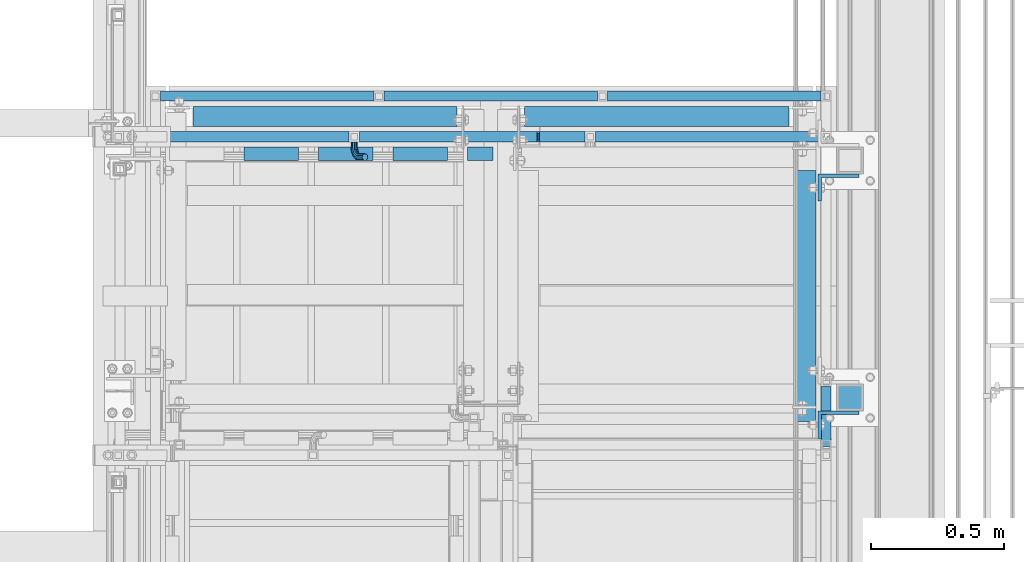
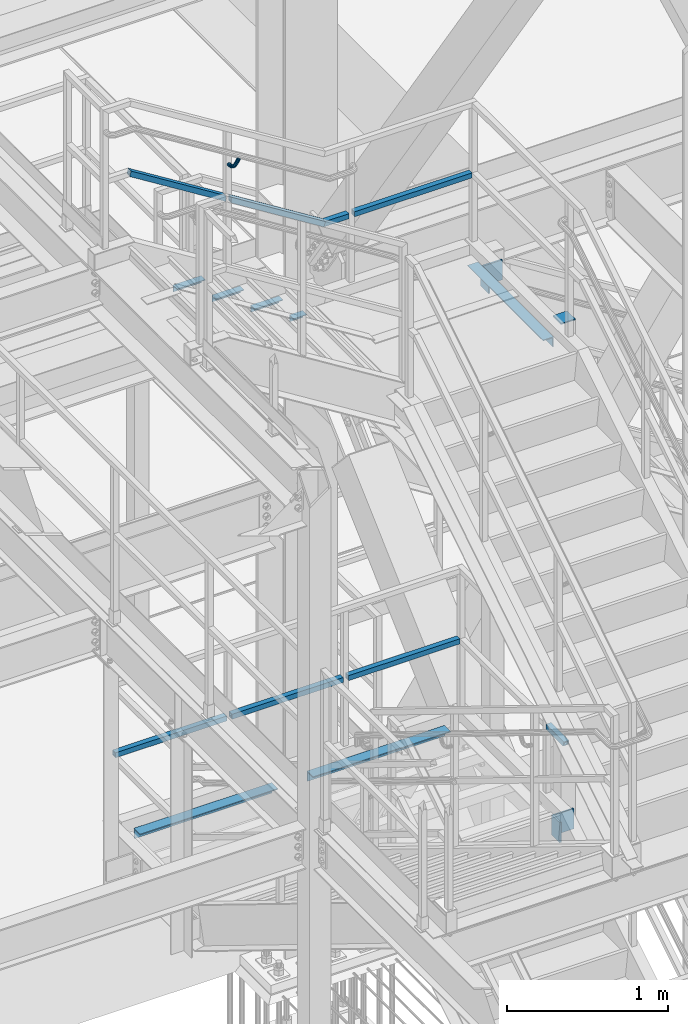
# One storey, part 2098 of 3843: 17 beams, 2 members, 8 elements without a shape of their own.
"""IFC2X3 building model written with IfcOpenShell, lengths in millimetres."""

from ifc_helpers import new_model, si_unit, frame, origin_with_axes, place, context, subcontext, project, spatial, faceted_brep, material, type_object, element, aggregate, save


model = new_model("IFC2X3")

# Units and contexts
model_context = context("Model", 3, precision=1e-05, world=origin_with_axes())
body_context = subcontext(model_context, "Body", "Model", "MODEL_VIEW")
ifc_project = project(units=[si_unit("LENGTHUNIT", "METRE", prefix="MILLI"), si_unit("AREAUNIT", "SQUARE_METRE"), si_unit("VOLUMEUNIT", "CUBIC_METRE"), si_unit("MASSUNIT", "GRAM", prefix="KILO"), si_unit("TIMEUNIT", "SECOND"), si_unit("PLANEANGLEUNIT", "RADIAN"), si_unit("SOLIDANGLEUNIT", "STERADIAN"), si_unit("THERMODYNAMICTEMPERATUREUNIT", "DEGREE_CELSIUS"), si_unit("LUMINOUSINTENSITYUNIT", "LUMEN")], contexts=[model_context])

# Site, building, storey
site_placement = place(None, origin_with_axes())
site = spatial("IfcSite", under=ifc_project, at=site_placement, CompositionType="ELEMENT")
building_placement = place(site_placement, origin_with_axes())
building = spatial("IfcBuilding", under=site, at=building_placement, Name="Undefined", CompositionType="ELEMENT")
storey_placement = place(building_placement, origin_with_axes())
storey = spatial("IfcBuildingStorey", under=building, at=storey_placement, Name="Undefined", CompositionType="ELEMENT", Elevation=0.0)

# Assembly, beams
assembly_1_placement = place(storey_placement, origin_with_axes())
assembly_1 = element("IfcElementAssembly", 1, at=assembly_1_placement, inside=storey, Name="RAIL", AssemblyPlace="NOTDEFINED", PredefinedType="RIGID_FRAME")
ifc_material_1 = material()
beam_type_1 = type_object("IfcBeamType", Name="HSS1-1/2X1-1/2X1/4", PredefinedType="NOTDEFINED")
beam_1_placement = place(assembly_1_placement, frame((54753.9333333087, 22910.8000000104, 37227.933331298), z_axis=(0.0, 0.0, 1.0), x_axis=(-1.0, 0.0, 0.0)))
beam_1 = element("IfcBeam", 2, at=beam_1_placement, type_object=beam_type_1, material=ifc_material_1, Name="RAIL", ObjectType="HSS1-1/2X1-1/2X1/4", context=body_context, shape_type="Brep", body=[
    faceted_brep([(19.0499992350015, -19.0499992350015, -19.0499992350015), (19.0499992350015, -19.0499992350015, 19.0499992350015), (19.0499992350015, 19.0499992350015, 19.0499992350015), (19.0499992350015, 19.0499992350015, -19.0499992350015), (19.0499992350015, 12.6999993299978, 12.6999993299978), (19.0499992350015, -12.6999993299978, 12.6999993299978), (19.0499992350015, -12.6999993299978, -12.6999993299978), (19.0499992350015, 12.6999993299978, -12.6999993299978), (200.1911839924, 19.0499992350015, -19.0499992350015), (200.1911839924, -19.0499992350015, -19.0499992350015), (189.275482698868, -19.0499992350015, 19.0499992350015), (189.275482698868, 19.0499992350015, 19.0499992350015), (191.094766293631, -12.6999993300014, 12.6999993299978), (191.094766293631, 12.6999993300014, 12.6999993299978), (198.371900397637, 12.6999993300014, -12.6999993299978), (198.371900397637, -12.6999993300014, -12.6999993299978)], [[[0, 1, 2, 3], [4, 5, 6, 7]], [[8, 9, 0, 3]], [[9, 10, 1, 0]], [[10, 11, 2, 1]], [[11, 8, 3, 2]], [[10, 9, 8, 11], [12, 13, 14, 15]], [[13, 12, 5, 4]], [[14, 13, 4, 7]], [[15, 14, 7, 6]], [[12, 15, 6, 5]]]),
])
beam_2_placement = place(assembly_1_placement, frame((55638.7, 22910.8000000047, 37227.933331298), z_axis=(0.0, 0.0, 1.0), x_axis=(-1.0, 0.0, 0.0)))
beam_2 = element("IfcBeam", 3, at=beam_2_placement, type_object=beam_type_1, material=ifc_material_1, Name="RAIL", ObjectType="HSS1-1/2X1-1/2X1/4", context=body_context, shape_type="Brep", body=[
    faceted_brep([(865.716666687869, -19.0500000104294, 19.0499992350015), (865.716666687869, -19.0499992350015, -19.0499992350015), (865.716666687869, 19.0499992350015, -19.0499992350015), (865.716666687869, 19.0499992518344, 19.0499992350015), (865.716666687869, -12.6999993300014, 12.6999993299978), (865.716666687869, 12.6999993300014, 12.6999993299978), (865.716666687869, 12.6999993300014, -12.6999993299978), (865.716666687869, -12.6999993300014, -12.6999993299978), (19.0499992350015, 19.0499992350015, -19.0499992350015), (19.0499992350015, 19.0499992350015, 19.0499992350015), (19.0499992350015, -19.0499992350015, 19.0499992350015), (19.0499992350015, -19.0499992350015, -19.0499992350015), (19.0499992350015, 12.6999993299978, 12.6999993299978), (19.0499992350015, -12.6999993299978, 12.6999993299978), (19.0499992350015, -12.6999993299978, -12.6999993299978), (19.0499992350015, 12.6999993299978, -12.6999993299978)], [[[0, 1, 2, 3], [4, 5, 6, 7]], [[8, 9, 3, 2]], [[9, 10, 0, 3]], [[10, 11, 1, 0]], [[11, 8, 2, 1]], [[11, 10, 9, 8], [12, 13, 14, 15]], [[14, 13, 4, 7]], [[15, 14, 7, 6]], [[12, 15, 6, 5]], [[13, 12, 5, 4]]]),
])

assembly_2_placement = place(storey_placement, origin_with_axes())
assembly_2 = element("IfcElementAssembly", 4, at=assembly_2_placement, inside=storey, Name="RAIL", AssemblyPlace="NOTDEFINED", PredefinedType="RIGID_FRAME")
beam_3_placement = place(assembly_2_placement, frame((53962.2999999994, 23063.2000000032, 33592.4769212707), z_axis=(0.0, 0.0, 1.0), x_axis=(1.0, 0.0, 0.0)))
beam_3 = element("IfcBeam", 5, at=beam_3_placement, type_object=beam_type_1, material=ifc_material_1, Name="RAIL", ObjectType="HSS1-1/2X1-1/2X1/4", context=body_context, shape_type="Brep", body=[
    faceted_brep([(19.0499992350015, 12.6999993299978, -12.6999993299978), (19.0499992350015, -12.6999993299978, -12.6999993299978), (819.150000000322, -12.6999993300014, -12.6999993299978), (819.150000000322, 12.6999993300014, -12.6999993299978), (19.0499992350015, -12.6999993299978, 12.6999993299978), (819.150000000322, -12.6999993300014, 12.6999993299978), (19.0499992350015, 12.6999993299978, 12.6999993299978), (819.150000000322, 12.6999993300014, 12.6999993299978), (19.0499992350015, 19.0499992350015, -19.0499992350015), (19.0499992350015, 19.0499992350015, 19.0499992350015), (819.150000000322, 19.0499992350015, 19.0499992350015), (819.150000000322, 19.0499992350015, -19.0499992350015), (19.0499992350015, -19.0499992350015, 19.0499992350015), (819.150000000322, -19.0499992350015, 19.0499992350015), (19.0499992350015, -19.0499992350015, -19.0499992350015), (819.150000000322, -19.0499992350015, -19.0499992350015)], [[[0, 1, 2, 3]], [[1, 4, 5, 2]], [[4, 6, 7, 5]], [[6, 0, 3, 7]], [[8, 9, 10, 11]], [[9, 12, 13, 10]], [[12, 14, 15, 13]], [[14, 8, 11, 15]], [[13, 15, 11, 10], [5, 7, 3, 2]], [[14, 12, 9, 8], [6, 4, 1, 0]]]),
])
beam_4_placement = place(assembly_2_placement, frame((53124.1, 23063.1999999956, 33592.4769213313), z_axis=(0.0, 0.0, 1.0), x_axis=(1.0, 0.0, 0.0)))
beam_4 = element("IfcBeam", 6, at=beam_4_placement, type_object=beam_type_1, material=ifc_material_1, Name="RAIL", ObjectType="HSS1-1/2X1-1/2X1/4", context=body_context, shape_type="Brep", body=[
    faceted_brep([(19.0499992350015, 12.6999993299978, -12.6999993299978), (19.0499992350015, -12.6999993299978, -12.6999993299978), (819.150000000322, -12.6999993300014, -12.6999993299978), (819.150000000322, 12.6999993300014, -12.6999993299978), (19.0499992350015, -12.6999993299978, 12.6999993299978), (819.150000000322, -12.6999993300014, 12.6999993299978), (19.0499992350015, 12.6999993299978, 12.6999993299978), (819.150000000322, 12.6999993300014, 12.6999993299978), (19.0499992350015, 19.0499992350015, -19.0499992350015), (19.0499992350015, 19.0499992350015, 19.0499992350015), (819.150000000322, 19.0499992350015, 19.0499992350015), (819.150000000322, 19.0499992350015, -19.0499992350015), (19.0499992350015, -19.0499992350015, 19.0499992350015), (819.150000000322, -19.0499992350015, 19.0499992350015), (19.0499992350015, -19.0499992350015, -19.0499992350015), (819.150000000322, -19.0499992350015, -19.0499992350015)], [[[0, 1, 2, 3]], [[1, 4, 5, 2]], [[4, 6, 7, 5]], [[6, 0, 3, 7]], [[8, 9, 10, 11]], [[9, 12, 13, 10]], [[12, 14, 15, 13]], [[14, 8, 11, 15]], [[13, 15, 11, 10], [5, 7, 3, 2]], [[14, 12, 9, 8], [6, 4, 1, 0]]]),
])
beam_5_placement = place(assembly_2_placement, frame((54800.4999999997, 23063.2000000032, 33592.4769212707), z_axis=(0.0, 0.0, 1.0), x_axis=(1.0, 0.0, 0.0)))
beam_5 = element("IfcBeam", 7, at=beam_5_placement, type_object=beam_type_1, material=ifc_material_1, Name="RAIL", ObjectType="HSS1-1/2X1-1/2X1/4", context=body_context, shape_type="Brep", body=[
    faceted_brep([(19.0499992350015, 12.6999993299978, -12.6999993299978), (19.0499992350015, -12.6999993299978, -12.6999993299978), (819.150000000322, -12.6999993300014, -12.6999993299978), (819.150000000322, 12.6999993300014, -12.6999993299978), (19.0499992350015, -12.6999993299978, 12.6999993299978), (819.150000000322, -12.6999993300014, 12.6999993299978), (19.0499992350015, 12.6999993299978, 12.6999993299978), (819.150000000322, 12.6999993300014, 12.6999993299978), (19.0499992350015, 19.0499992350015, -19.0499992350015), (19.0499992350015, 19.0499992350015, 19.0499992350015), (819.150000000322, 19.0499992350015, 19.0499992350015), (819.150000000322, 19.0499992350015, -19.0499992350015), (19.0499992350015, -19.0499992350015, 19.0499992350015), (819.150000000322, -19.0499992350015, 19.0499992350015), (19.0499992350015, -19.0499992350015, -19.0499992350015), (819.150000000322, -19.0499992350015, -19.0499992350015)], [[[0, 1, 2, 3]], [[1, 4, 5, 2]], [[4, 6, 7, 5]], [[6, 0, 3, 7]], [[8, 9, 10, 11]], [[9, 12, 13, 10]], [[12, 14, 15, 13]], [[14, 8, 11, 15]], [[13, 15, 11, 10], [5, 7, 3, 2]], [[14, 12, 9, 8], [6, 4, 1, 0]]]),
])
aggregate(assembly_2, [beam_3, beam_4, beam_5])

# Assembly, beam
assembly_3_placement = place(storey_placement, origin_with_axes())
assembly_3 = element("IfcElementAssembly", 8, at=assembly_3_placement, inside=storey, Name="RAIL", AssemblyPlace="NOTDEFINED", PredefinedType="RIGID_FRAME")
beam_6_placement = place(assembly_3_placement, frame((55638.6999999997, 21755.1000004885, 33592.4769212975), z_axis=(0.0, 0.0, 1.0), x_axis=(0.0, 1.0, 0.0)))
beam_6 = element("IfcBeam", 9, at=beam_6_placement, type_object=beam_type_1, material=ifc_material_1, Name="RAIL", ObjectType="HSS1-1/2X1-1/2X1/4", context=body_context, shape_type="Brep", body=[
    faceted_brep([(3.59463564452017, 12.6999993300014, -12.6999993299978), (3.59463564452017, -12.6999993300014, -12.6999993299978), (219.075000274512, -12.6999993299978, -12.6999993299978), (219.075000274512, 12.6999993299978, -12.6999993299978), (-3.59463560431323, -12.6999993300014, 12.6999993299978), (219.075000274512, -12.6999993299978, 12.6999993299978), (-3.59463560431323, 12.6999993300014, 12.6999993299978), (219.075000274512, 12.6999993299978, 12.6999993299978), (5.39195352466777, 19.0499992350015, -19.0499992350015), (-5.39195348444628, 19.0499992350015, 19.0499992350015), (219.075000274512, 19.0499992350015, 19.0499992350015), (219.075000274512, 19.0499992350015, -19.0499992350015), (-5.39195348444628, -19.0499992350015, 19.0499992350015), (219.075000274512, -19.0499992350015, 19.0499992350015), (5.39195352466777, -19.0499992350015, -19.0499992350015), (219.075000274512, -19.0499992350015, -19.0499992350015)], [[[0, 1, 2, 3]], [[1, 4, 5, 2]], [[4, 6, 7, 5]], [[6, 0, 3, 7]], [[8, 9, 10, 11]], [[9, 12, 13, 10]], [[12, 14, 15, 13]], [[14, 8, 11, 15]], [[13, 15, 11, 10], [5, 7, 3, 2]], [[14, 12, 9, 8], [6, 4, 1, 0]]]),
])
aggregate(assembly_3, [beam_6])

assembly_4_placement = place(storey_placement, origin_with_axes())
assembly_4 = element("IfcElementAssembly", 10, at=assembly_4_placement, inside=storey, Name="POST", AssemblyPlace="NOTDEFINED", PredefinedType="RIGID_FRAME")
ifc_material_2 = material(Name="STEEL/A36")
beam_type_2 = type_object("IfcBeamType", Name="L6X4X1/2", PredefinedType="NOTDEFINED")
beam_7_placement = place(assembly_4_placement, frame((55684.737500001, 21831.3000000032, 32982.8769213273), z_axis=(1.0, 0.0, 0.0), x_axis=(0.0, 0.0, -1.0)))
beam_7 = element("IfcBeam", 11, at=beam_7_placement, type_object=beam_type_2, material=ifc_material_2, Name="ANGLE", ObjectType="L6X4X1/2", context=body_context, shape_type="Brep", body=[
    faceted_brep([(0.0, 50.7999999999993, -76.1999999999971), (0.0, 50.7999999999993, 76.1999999999971), (152.399999999994, 50.7999999999993, 76.1999999999971), (152.399999999994, 50.7999999999993, -76.1999999999971), (0.0, 38.0999999999985, 76.1999999999971), (152.399999999994, 38.0999999999985, 76.1999999999971), (0.0, 38.0999999999985, -63.5), (152.399999999994, 38.0999999999985, -63.5), (0.0, -50.7999999999993, -63.5), (152.399999999994, -50.7999999999993, -63.5), (0.0, -50.7999999999993, -76.1999999999971), (152.399999999994, -50.7999999999993, -76.1999999999971)], [[[0, 1, 2, 3]], [[1, 4, 5, 2]], [[4, 6, 7, 5]], [[6, 8, 9, 7]], [[8, 10, 11, 9]], [[10, 0, 3, 11]], [[5, 7, 9, 11, 3, 2]], [[10, 8, 6, 4, 1, 0]]]),
])

assembly_5_placement = place(storey_placement, origin_with_axes())
assembly_5 = element("IfcElementAssembly", 12, at=assembly_5_placement, inside=storey, Name="POST", AssemblyPlace="NOTDEFINED", PredefinedType="RIGID_FRAME")
beam_8_placement = place(assembly_5_placement, frame((55684.737500001, 22720.3000000818, 36618.3333313492), z_axis=(1.0, 0.0, 0.0), x_axis=(0.0, 0.0, -1.0)))
beam_8 = element("IfcBeam", 13, at=beam_8_placement, type_object=beam_type_2, material=ifc_material_2, Name="ANGLE", ObjectType="L6X4X1/2", context=body_context, shape_type="Brep", body=[
    faceted_brep([(0.0, 50.7999999999993, -76.1999999999971), (0.0, 50.7999999999993, 76.1999999999971), (152.399999999994, 50.7999999999993, 76.1999999999971), (152.399999999994, 50.7999999999993, -76.1999999999971), (0.0, 38.0999999999985, 76.1999999999971), (152.399999999994, 38.0999999999985, 76.1999999999971), (0.0, 38.0999999999985, -63.5), (152.399999999994, 38.0999999999985, -63.5), (0.0, -50.7999999999993, -63.5), (152.399999999994, -50.7999999999993, -63.5), (0.0, -50.7999999999993, -76.1999999999971), (152.399999999994, -50.7999999999993, -76.1999999999971)], [[[0, 1, 2, 3]], [[1, 4, 5, 2]], [[4, 6, 7, 5]], [[6, 8, 9, 7]], [[8, 10, 11, 9]], [[10, 0, 3, 11]], [[5, 7, 9, 11, 3, 2]], [[10, 8, 6, 4, 1, 0]]]),
])
aggregate(assembly_5, [beam_8])

# Member
member_type = type_object("IfcMemberType", Name="HSS1-1/2X1-1/2X1/4", PredefinedType="NOTDEFINED")
member_1_placement = place(assembly_1_placement, frame((53869.1666666233, 22910.8000000151, 37658.6814120453), z_axis=(0.529536736899108, 0.0, 0.848287005838381), x_axis=(-0.848287005838377, 0.0, 0.529536736899114)))
member_1 = element("IfcMember", 14, at=member_1_placement, type_object=member_type, material=ifc_material_1, Name="RAIL", ObjectType="HSS1-1/2X1-1/2X1/4", context=body_context, shape_type="Brep", body=[
    faceted_brep([(34.3488397583606, -19.0499999999956, 19.0499992348923), (34.3488397583606, 19.0499992350015, 19.0499992348923), (10.5652043534537, 19.0499992350015, -19.0499992349432), (10.5652043534537, -19.0499992350015, -19.0499992349432), (30.3849004243275, -12.6999993300014, 12.6999993299178), (14.5291436874832, -12.6999993300014, -12.6999993299687), (14.5291436874832, 12.6999993300014, -12.6999993299687), (30.3849004243275, 12.6999993300014, 12.6999993299178), (827.947191084055, 19.0499992350015, -19.0499992358964), (827.947191084055, -19.0499992350015, -19.0499992358964), (838.862892383193, -19.0499992350015, 19.049999233961), (838.862892383193, 19.0499992350015, 19.049999233961), (837.043608787495, -12.6999993300014, 12.6999993289792), (837.043608787495, 12.6999993300014, 12.6999993289792), (829.766474679749, 12.6999993300014, -12.6999993309219), (829.766474679749, -12.6999993300014, -12.6999993309219)], [[[0, 1, 2, 3], [4, 5, 6, 7]], [[8, 9, 3, 2]], [[9, 10, 0, 3]], [[10, 11, 1, 0]], [[11, 8, 2, 1]], [[10, 9, 8, 11], [12, 13, 14, 15]], [[13, 12, 4, 7]], [[14, 13, 7, 6]], [[15, 14, 6, 5]], [[12, 15, 5, 4]]]),
])

member_2_placement = place(assembly_1_placement, frame((54559.1999999617, 22910.8000000151, 37227.933331298), z_axis=(0.529536736899108, 0.0, 0.848287005838381), x_axis=(-0.848287005838377, 0.0, 0.529536736899114)))
member_2 = element("IfcMember", 15, at=member_2_placement, type_object=member_type, material=ifc_material_1, Name="RAIL", ObjectType="HSS1-1/2X1-1/2X1/4", context=body_context, shape_type="Brep", body=[
    faceted_brep([(802.87803901095, -19.0499999999993, 19.0499992339901), (779.094403606043, -19.0499992350015, -19.0499992358382), (779.094403606043, 19.0499992350015, -19.0499992358382), (802.87803901095, 19.0499992350015, 19.0499992339901), (798.914099676924, -12.6999993300014, 12.6999993290228), (798.914099676924, 12.6999993300014, 12.6999993290228), (783.058342940076, 12.6999993300014, -12.6999993308709), (783.058342940076, -12.6999993300014, -12.6999993308709), (5.45785064817028, 19.0499992350015, 19.0499992349287), (5.45785064817028, -19.0499992350015, 19.0499992349287), (-5.45785065095697, -19.0499992350015, -19.0499992349214), (-5.45785065095697, 19.0499992350015, -19.0499992349214), (3.63856705247599, 12.6999993300014, 12.6999993299542), (3.63856705247599, -12.6999993300014, 12.6999993299542), (-3.63856705526268, -12.6999993300014, -12.6999993299469), (-3.63856705526268, 12.6999993300014, -12.6999993299469)], [[[0, 1, 2, 3], [4, 5, 6, 7]], [[8, 9, 0, 3]], [[10, 11, 2, 1]], [[9, 10, 1, 0]], [[11, 8, 3, 2]], [[10, 9, 8, 11], [12, 13, 14, 15]], [[14, 13, 4, 7]], [[15, 14, 7, 6]], [[12, 15, 6, 5]], [[13, 12, 5, 4]]]),
])

# Assembly, beams
assembly_6_placement = place(storey_placement, origin_with_axes())
assembly_6 = element("IfcElementAssembly", 16, at=assembly_6_placement, inside=storey, Name="STAIR", AssemblyPlace="NOTDEFINED", PredefinedType="RIGID_FRAME")
beam_type_3 = type_object("IfcBeamType", Name="L2X2X3/16", PredefinedType="NOTDEFINED")
beam_9_placement = place(assembly_6_placement, frame((54294.5934500262, 22847.299999903, 36618.3200647423), z_axis=(0.0, -1.0, 0.0), x_axis=(1.0, 0.0, 0.0)))
beam_9 = element("IfcBeam", 17, at=beam_9_placement, type_object=beam_type_3, material=ifc_material_2, Name="ANGLE", ObjectType="L2X2X3/16", context=body_context, shape_type="Brep", body=[
    faceted_brep([(0.0, 25.4000000000015, -25.4000000000015), (0.0, 25.4000000000015, 25.4000000000015), (95.25, 25.4000000000015, 25.4000000000015), (95.25, 25.4000000000015, -25.4000000000015), (0.0, 20.6375000000007, 25.4000000000015), (95.25, 20.6374999999971, 25.4000000000015), (0.0, 20.6375000000007, -20.6375000000007), (95.25, 20.6374999999971, -20.6375000000007), (0.0, -25.4000000000015, -20.6375000000007), (95.25, -25.4000000000015, -20.6375000000007), (0.0, -25.4000000000015, -25.4000000000015), (95.25, -25.4000000000015, -25.4000000000015)], [[[0, 1, 2, 3]], [[1, 4, 5, 2]], [[4, 6, 7, 5]], [[6, 8, 9, 7]], [[8, 10, 11, 9]], [[10, 0, 3, 11]], [[5, 7, 9, 11, 3, 2]], [[10, 8, 6, 4, 1, 0]]]),
])
ifc_material_3 = material(Name="STEEL/A572-50")
beam_10_placement = place(assembly_6_placement, frame((53456.3934500501, 22847.3000000165, 37138.3983316229), z_axis=(0.0, -1.0, 0.0), x_axis=(1.0, 0.0, 0.0)))
beam_10 = element("IfcBeam", 18, at=beam_10_placement, type_object=beam_type_3, material=ifc_material_3, Name="ANGLE", ObjectType="L2X2X3/16", context=body_context, shape_type="Brep", body=[
    faceted_brep([(0.0, 25.4000000000015, -25.4000000000015), (0.0, 25.4000000000015, 25.4000000000015), (203.199999999997, 25.4000000000015, 25.4000000000015), (203.199999999997, 25.4000000000015, -25.4000000000015), (0.0, 20.6375000000007, 25.4000000000015), (203.199999999997, 20.6375000000007, 25.4000000000015), (0.0, 20.6375000000007, -20.6375000000007), (203.199999999997, 20.6375000000007, -20.6375000000007), (0.0, -25.4000000000015, -20.6375000000007), (203.199999999997, -25.4000000000015, -20.6375000000007), (0.0, -25.4000000000015, -25.4000000000015), (203.199999999997, -25.4000000000015, -25.4000000000015)], [[[0, 1, 2, 3]], [[1, 4, 5, 2]], [[4, 6, 7, 5]], [[6, 8, 9, 7]], [[8, 10, 11, 9]], [[10, 0, 3, 11]], [[5, 7, 9, 11, 3, 2]], [[10, 8, 6, 4, 1, 0]]]),
])
beam_11_placement = place(assembly_6_placement, frame((53735.7934500472, 22847.3000000158, 36963.9849981808), z_axis=(0.0, -1.0, 0.0), x_axis=(1.0, 0.0, 0.0)))
beam_11 = element("IfcBeam", 19, at=beam_11_placement, type_object=beam_type_3, material=ifc_material_3, Name="ANGLE", ObjectType="L2X2X3/16", context=body_context, shape_type="Brep", body=[
    faceted_brep([(0.0, 25.4000000000015, -25.4000000000015), (0.0, 25.4000000000015, 25.4000000000015), (203.199999999997, 25.4000000000015, 25.4000000000015), (203.199999999997, 25.4000000000015, -25.4000000000015), (0.0, 20.6375000000007, 25.4000000000015), (203.199999999997, 20.6375000000007, 25.4000000000015), (0.0, 20.6375000000007, -20.6375000000007), (203.199999999997, 20.6375000000007, -20.6375000000007), (0.0, -25.4000000000015, -20.6375000000007), (203.199999999997, -25.4000000000015, -20.6375000000007), (0.0, -25.4000000000015, -25.4000000000015), (203.199999999997, -25.4000000000015, -25.4000000000015)], [[[0, 1, 2, 3]], [[1, 4, 5, 2]], [[4, 6, 7, 5]], [[6, 8, 9, 7]], [[8, 10, 11, 9]], [[10, 0, 3, 11]], [[5, 7, 9, 11, 3, 2]], [[10, 8, 6, 4, 1, 0]]]),
])
beam_12_placement = place(assembly_6_placement, frame((54015.1934500443, 22847.300000015, 36789.5716647387), z_axis=(0.0, -1.0, 0.0), x_axis=(1.0, 0.0, 0.0)))
beam_12 = element("IfcBeam", 20, at=beam_12_placement, type_object=beam_type_3, material=ifc_material_3, Name="ANGLE", ObjectType="L2X2X3/16", context=body_context, shape_type="Brep", body=[
    faceted_brep([(0.0, 25.4000000000015, -25.4000000000015), (0.0, 25.4000000000015, 25.4000000000015), (203.199999999997, 25.4000000000015, 25.4000000000015), (203.199999999997, 25.4000000000015, -25.4000000000015), (0.0, 20.6375000000007, 25.4000000000015), (203.199999999997, 20.6375000000007, 25.4000000000015), (0.0, 20.6375000000007, -20.6375000000007), (203.199999999997, 20.6375000000007, -20.6375000000007), (0.0, -25.4000000000015, -20.6375000000007), (203.199999999997, -25.4000000000015, -20.6375000000007), (0.0, -25.4000000000015, -25.4000000000015), (203.199999999997, -25.4000000000015, -25.4000000000015)], [[[0, 1, 2, 3]], [[1, 4, 5, 2]], [[4, 6, 7, 5]], [[6, 8, 9, 7]], [[8, 10, 11, 9]], [[10, 0, 3, 11]], [[5, 7, 9, 11, 3, 2]], [[10, 8, 6, 4, 1, 0]]]),
])
aggregate(assembly_6, [beam_9, beam_10, beam_11, beam_12])

# Beam
beam_type_4 = type_object("IfcBeamType", PredefinedType="NOTDEFINED")
beam_13_placement = place(assembly_1_placement, frame((53869.1002048289, 22891.7500000151, 37927.4377896367), z_axis=(-0.848287005838377, 0.0, 0.529536736899114), x_axis=(0.0, -1.0, 0.0)))
beam_13 = element("IfcBeam", 21, at=beam_13_placement, type_object=beam_type_4, material=ifc_material_2, Name="BRACKET ARM", context=body_context, shape_type="Brep", body=[
    faceted_brep([(0.0, -12.6999999999971, 0.0), (0.0, -10.9985226280696, -6.34999999999854), (19.0500015258731, -10.9985226280623, -6.34999999999854), (19.0500015258731, -12.6999999999971, -6.33008312433958e-10), (0.0, -6.35000000000582, -10.9985226280623), (19.0500015258731, -6.34999999999854, -10.9985226280623), (0.0, 0.0, -12.6999999999971), (19.0500015258731, 0.0, -12.6999999999971), (0.0, 6.35000000000582, -10.9985226280623), (19.0500015258731, 6.34999999999854, -10.9985226280623), (0.0, 10.9985226280696, -6.34999999999854), (19.0500015258731, 10.9985226280623, -6.34999999999854), (0.0, 12.6999999999971, 0.0), (19.0500015258731, 12.6999999999971, 0.0), (0.0, 10.9985226280696, 6.34999999999854), (19.0500015258731, 10.9985226280623, 6.34999999999854), (0.0, 6.35000000000582, 10.9985226280623), (19.0500015258731, 6.34999999999854, 10.9985226280623), (0.0, 0.0, 12.6999999999971), (19.0500015258731, 0.0, 12.6999999999971), (0.0, -6.35000000000582, 10.9985226280623), (19.0500015258731, -6.34999999999854, 10.9985226280623), (0.0, -10.9985226280696, 6.34999999999854), (19.0500015258731, -10.9985226280623, 6.34999999999854), (38.4903193060891, -8.8330803677236, -3.34694050252438e-10), (37.8391921052389, -7.26112024908798, 6.34999999974389), (36.0602795104642, -2.96644533684594, 10.9985226280041), (33.6302397149266, 2.90018969451194, 12.7000000002226), (31.2001999194181, 8.76682472604443, 10.9985226285644), (29.4212873247307, 13.061499638774, 6.35000000070431), (28.7701601240115, 14.6334597580644, 7.78527464717627e-10), (29.4212873248762, 13.0614996394288, -6.34999999929278), (31.2001999196509, 8.76682472718676, -10.9985226275603), (33.6302397151885, 2.90018969582889, -12.6999999997788), (36.0602795106824, -2.96644533571089, -10.9985226281206), (37.8391921053699, -7.26112024843314, -6.35000000026048), (53.7678987435793, 3.38210125690239, -6.3499999994383), (54.9710249311902, 2.17897506880399, 5.0931703299284e-10), (50.4808968708676, 6.66910312997061, -10.9985226273784), (45.9907688103704, 11.1592311906061, -12.6999999991458), (41.5006407498004, 15.6493592510378, -10.9985226270364), (38.213638876914, 18.9363611235749, -6.34999999884167), (37.0105126890558, 20.1394873109457, 1.20053300634027e-09), (38.2136388766667, 18.9363611228473, 6.35000000115542), (41.5006407493784, 15.6493592497718, 10.9985226290883), (45.9907688098756, 11.1592311891436, 12.7000000008557), (50.4808968704456, 6.66910312870459, 10.9985226287463), (53.7678987433319, 3.38210125617479, 6.35000000055879), (64.4111202489148, 19.3108078951118, -6.34999999821594), (65.9830803677178, 18.6596806939051, 1.77533365786076e-09), (60.1164453365491, 21.0897204901557, -10.9985226262725), (54.2498103051475, 23.5197602857806, -12.6999999981927), (48.3831752736587, 25.9498000811873, -10.9985226262434), (44.0885003610601, 27.7287126756128, -6.34999999817228), (42.516540241937, 28.3798398759754, 1.83354131877422e-09), (44.08850036074, 27.7287126747688, 6.35000000183209), (48.3831752731057, 25.9498000797321, 10.9985226298813), (54.2498103045073, 23.5197602840999, 12.7000000018088), (60.1164453359961, 21.0897204886933, 10.9985226298522), (64.4111202485947, 19.3108078942678, 6.35000000178115), (68.1485226282239, 38.0999984746086, -6.3499999967753), (69.8499999999913, 38.0999984741211, 2.92493496090174e-09), (63.500000000291, 38.0999984749651, -10.9985226249628), (57.1500000003434, 38.0999984750961, -12.6999999970722), (50.8000000002939, 38.0999984749651, -10.998522625312), (46.1514773720992, 38.0999984746086, -6.34999999737192), (44.4499999999971, 38.0999984741211, 2.58296495303512e-09), (46.1514773717645, 38.0999984736336, 6.35000000262517), (50.7999999996973, 38.0999984732771, 10.9985226308127), (57.1499999996449, 38.0999984731461, 12.700000002922), (63.4999999996944, 38.0999984732771, 10.9985226311619), (68.1485226278892, 38.0999984736336, 6.35000000322179), (68.1485226280638, 76.2000000002372, -6.34999999414867), (69.8499999999913, 76.199999999757, 5.84986992180347e-09), (63.5, 76.200000000601, -10.9985226222125), (57.1499999999942, 76.2000000007247, -12.6999999941472), (50.7999999999884, 76.200000000601, -10.9985226222125), (46.1514773719246, 76.2000000002372, -6.34999999414867), (44.4499999999971, 76.199999999757, 5.84986992180347e-09), (46.1514773719246, 76.1999999992695, 6.35000000584841), (50.7999999999884, 76.1999999989057, 10.9985226339122), (57.1499999999942, 76.199999998782, 12.700000005847), (63.5, 76.1999999989057, 10.9985226339122), (68.1485226280638, 76.1999999992695, 6.35000000584841)], [[[0, 1, 2, 3]], [[1, 4, 5, 2]], [[4, 6, 7, 5]], [[6, 8, 9, 7]], [[8, 10, 11, 9]], [[10, 12, 13, 11]], [[12, 14, 15, 13]], [[14, 16, 17, 15]], [[16, 18, 19, 17]], [[18, 20, 21, 19]], [[20, 22, 23, 21]], [[22, 0, 3, 23]], [[22, 20, 18, 16, 14, 12, 10, 8, 6, 4, 1, 0]], [[23, 3, 24, 25]], [[21, 23, 25, 26]], [[19, 21, 26, 27]], [[17, 19, 27, 28]], [[15, 17, 28, 29]], [[13, 15, 29, 30]], [[11, 13, 30, 31]], [[9, 11, 31, 32]], [[7, 9, 32, 33]], [[5, 7, 33, 34]], [[2, 5, 34, 35]], [[3, 2, 35, 24]], [[35, 36, 37, 24]], [[34, 38, 36, 35]], [[33, 39, 38, 34]], [[32, 40, 39, 33]], [[31, 41, 40, 32]], [[30, 42, 41, 31]], [[29, 43, 42, 30]], [[28, 44, 43, 29]], [[27, 45, 44, 28]], [[26, 46, 45, 27]], [[25, 47, 46, 26]], [[24, 37, 47, 25]], [[36, 48, 49, 37]], [[38, 50, 48, 36]], [[39, 51, 50, 38]], [[40, 52, 51, 39]], [[41, 53, 52, 40]], [[42, 54, 53, 41]], [[43, 55, 54, 42]], [[44, 56, 55, 43]], [[45, 57, 56, 44]], [[46, 58, 57, 45]], [[47, 59, 58, 46]], [[37, 49, 59, 47]], [[48, 60, 61, 49]], [[50, 62, 60, 48]], [[51, 63, 62, 50]], [[52, 64, 63, 51]], [[53, 65, 64, 52]], [[54, 66, 65, 53]], [[55, 67, 66, 54]], [[56, 68, 67, 55]], [[57, 69, 68, 56]], [[58, 70, 69, 57]], [[59, 71, 70, 58]], [[49, 61, 71, 59]], [[61, 60, 72, 73]], [[60, 62, 74, 72]], [[62, 63, 75, 74]], [[63, 64, 76, 75]], [[64, 65, 77, 76]], [[65, 66, 78, 77]], [[66, 67, 79, 78]], [[67, 68, 80, 79]], [[68, 69, 81, 80]], [[69, 70, 82, 81]], [[70, 71, 83, 82]], [[71, 61, 73, 83]], [[74, 75, 76, 77, 78, 79, 80, 81, 82, 83, 73, 72]]]),
])

aggregate(assembly_1, [beam_13, beam_1, beam_2, member_1, member_2])

# Assembly, beam
assembly_7_placement = place(storey_placement, origin_with_axes())
assembly_7 = element("IfcElementAssembly", 22, at=assembly_7_placement, inside=storey, Name="STAIR", AssemblyPlace="NOTDEFINED", PredefinedType="RIGID_FRAME")
beam_type_5 = type_object("IfcBeamType", Name="L3X3X1/4", PredefinedType="NOTDEFINED")
beam_14_placement = place(assembly_7_placement, frame((55562.499999919, 22783.8000000001, 36605.6333313786), z_axis=(-1.0, 0.0, 0.0), x_axis=(0.0, -1.0, 0.0)))
beam_14 = element("IfcBeam", 23, at=beam_14_placement, type_object=beam_type_5, material=ifc_material_2, Name="ANGLE", ObjectType="L3X3X1/4", context=body_context, shape_type="Brep", body=[
    faceted_brep([(711.200000012595, -38.0999999983105, -31.75), (711.200000012595, -38.0999999999985, -38.0999999999985), (711.19999997268, 31.749999993699, -38.0999999999985), (711.19999997268, 31.75, -31.75), (787.40000012911, 31.7499999936408, -38.0999999999985), (787.40000012911, 31.75, -31.75), (787.400000169026, -38.0999999829946, -31.75), (787.400000169026, -38.0999999999985, -38.0999999999985), (101.600000050574, 31.75, -31.75), (101.60000008007, -38.0999999938067, -31.75), (101.60000008007, -38.0999999999985, -38.0999999999985), (939.799999962997, -38.0999999999985, -38.0999999999985), (939.799999962997, -38.0999999999985, -31.75), (101.600000050574, 31.7499999828287, -38.0999999999985), (0.0, 31.7500000838336, -38.0999999999985), (0.0, 38.0999999999985, -38.0999999999985), (939.800000000141, 38.0999999999985, -38.0999999999985), (0.0, 31.75, -31.75), (0.0, 31.75, 38.0999999999985), (0.0, 38.0999999999985, 38.0999999999985), (101.600000050574, 31.75, 38.0999999999985), (711.19999997268, 31.75, 38.0999999999985), (787.40000012911, 31.75, 38.0999999999985), (939.799999962997, 31.75, 38.0999999999985), (939.799999962997, 38.0999999999985, 38.0999999999985), (939.799999962997, 31.75, -31.75)], [[[0, 1, 2, 3]], [[3, 2, 4, 5]], [[6, 5, 4, 7]], [[8, 9, 0, 3]], [[9, 10, 1, 0]], [[11, 12, 6, 7]], [[2, 1, 10, 13, 14, 15, 16, 11, 7, 4]], [[9, 8, 13, 10]], [[17, 14, 13, 8]], [[18, 19, 15, 14, 17]], [[19, 18, 20, 21, 22, 23, 24]], [[15, 19, 24, 16]], [[23, 25, 12, 11, 16, 24]], [[22, 21, 20, 18, 17, 8, 3, 5, 25, 23]], [[12, 25, 5, 6]]]),
])
aggregate(assembly_7, [beam_14])

# Assembly, beams
assembly_8_placement = place(storey_placement, origin_with_axes())
assembly_8 = element("IfcElementAssembly", 24, at=assembly_8_placement, inside=storey, Name="STAIR", AssemblyPlace="NOTDEFINED", PredefinedType="RIGID_FRAME")
beam_15_placement = place(assembly_8_placement, frame((54508.4000208372, 22987.0000000007, 32970.1768437114), z_axis=(0.0, -1.0, 0.0), x_axis=(1.0, 0.0, 0.0)))
beam_15 = element("IfcBeam", 25, at=beam_15_placement, type_object=beam_type_5, material=ifc_material_2, Name="ANGLE", ObjectType="L3X3X1/4", context=body_context, shape_type="Brep", body=[
    faceted_brep([(0.0, 38.0999999999985, -38.0999999999985), (0.0, 38.0999999999985, 38.0999999999985), (990.600000450311, 38.0999999999985, 38.1000000000058), (990.600000450311, 38.0999999999985, -38.1000000000058), (0.0, 31.75, 38.0999999999985), (990.600000450311, 31.75, 38.1000000000058), (0.0, 31.75, -31.75), (990.600000450311, 31.75, -31.75), (0.0, -38.0999999999985, -31.75), (990.600000450311, -38.0999999999985, -31.75), (0.0, -38.0999999999985, -38.0999999999985), (990.600000450311, -38.0999999999985, -38.1000000000058)], [[[0, 1, 2, 3]], [[1, 4, 5, 2]], [[4, 6, 7, 5]], [[6, 8, 9, 7]], [[8, 10, 11, 9]], [[10, 0, 3, 11]], [[5, 7, 9, 11, 3, 2]], [[10, 8, 6, 4, 1, 0]]]),
])
beam_16_placement = place(assembly_8_placement, frame((53263.7999985709, 22987.0000000006, 32970.1769213185), z_axis=(0.0, -1.0, 0.0), x_axis=(1.0, 0.0, 0.0)))
beam_16 = element("IfcBeam", 26, at=beam_16_placement, type_object=beam_type_5, material=ifc_material_2, Name="ANGLE", ObjectType="L3X3X1/4", context=body_context, shape_type="Brep", body=[
    faceted_brep([(0.0, 38.0999999999985, -38.0999999999985), (0.0, 38.0999999999985, 38.0999999999985), (990.600000450311, 38.0999999999985, 38.1000000000058), (990.600000450311, 38.0999999999985, -38.1000000000058), (0.0, 31.75, 38.0999999999985), (990.600000450311, 31.75, 38.1000000000058), (0.0, 31.75, -31.75), (990.600000450311, 31.75, -31.75), (0.0, -38.0999999999985, -31.75), (990.600000450311, -38.0999999999985, -31.75), (0.0, -38.0999999999985, -38.0999999999985), (990.600000450311, -38.0999999999985, -38.1000000000058)], [[[0, 1, 2, 3]], [[1, 4, 5, 2]], [[4, 6, 7, 5]], [[6, 8, 9, 7]], [[8, 10, 11, 9]], [[10, 0, 3, 11]], [[5, 7, 9, 11, 3, 2]], [[10, 8, 6, 4, 1, 0]]]),
])
aggregate(assembly_8, [beam_15, beam_16])

# Beam
beam_type_6 = type_object("IfcBeamType", PredefinedType="NOTDEFINED")
beam_17_placement = place(assembly_4_placement, frame((55778.3999999994, 21932.9000000032, 36689.7708313031), z_axis=(0.0, 1.0, 0.0), x_axis=(-1.0, 0.0, 0.0)))
beam_17 = element("IfcBeam", 27, at=beam_17_placement, type_object=beam_type_6, material=ifc_material_2, Name="PLATE", context=body_context, shape_type="Brep", body=[
    faceted_brep([(0.0, 4.76249999999709, -50.7999999999993), (0.0, 4.76249999999709, 50.7999999999993), (101.600000000006, 4.76249999999709, 50.7999999999993), (101.600000000006, 4.76249999999709, -50.7999999999993), (0.0, -4.76249999999709, 50.7999999999993), (101.600000000006, -4.76249999999709, 50.7999999999993), (0.0, -4.76249999999709, -50.7999999999993), (101.600000000006, -4.76249999999709, -50.7999999999993)], [[[0, 1, 2, 3]], [[1, 4, 5, 2]], [[4, 6, 7, 5]], [[6, 0, 3, 7]], [[5, 7, 3, 2]], [[6, 4, 1, 0]]]),
])

aggregate(assembly_4, [beam_7, beam_17])

save(model, "model.ifc")
